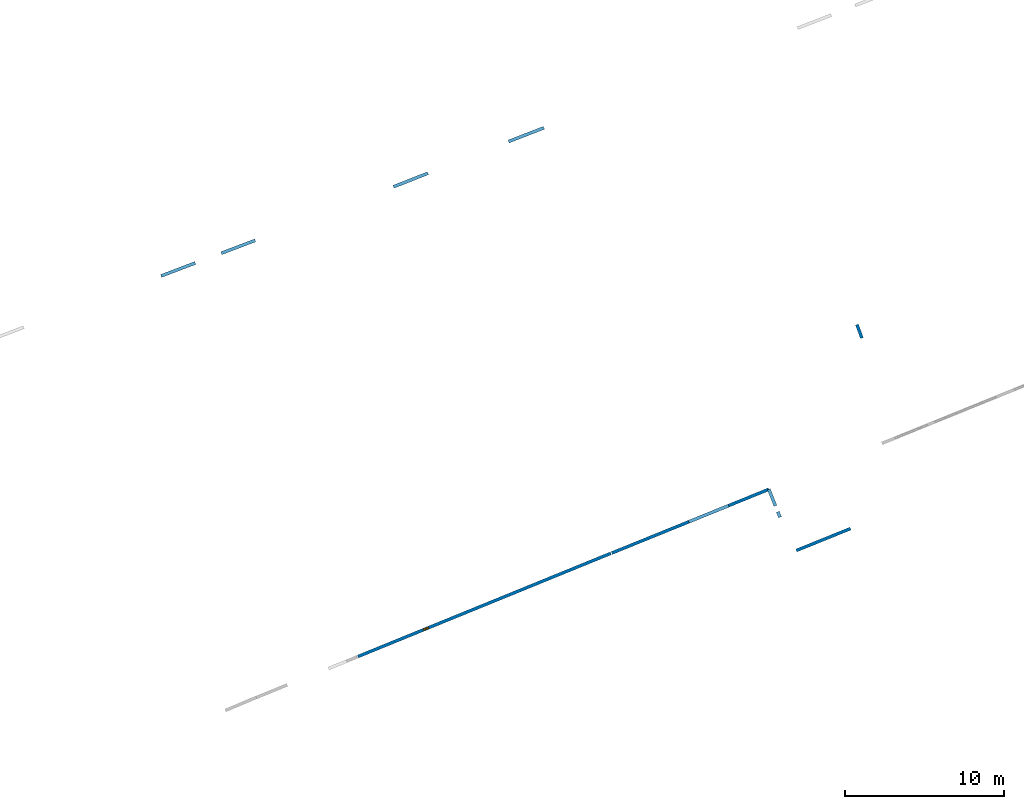
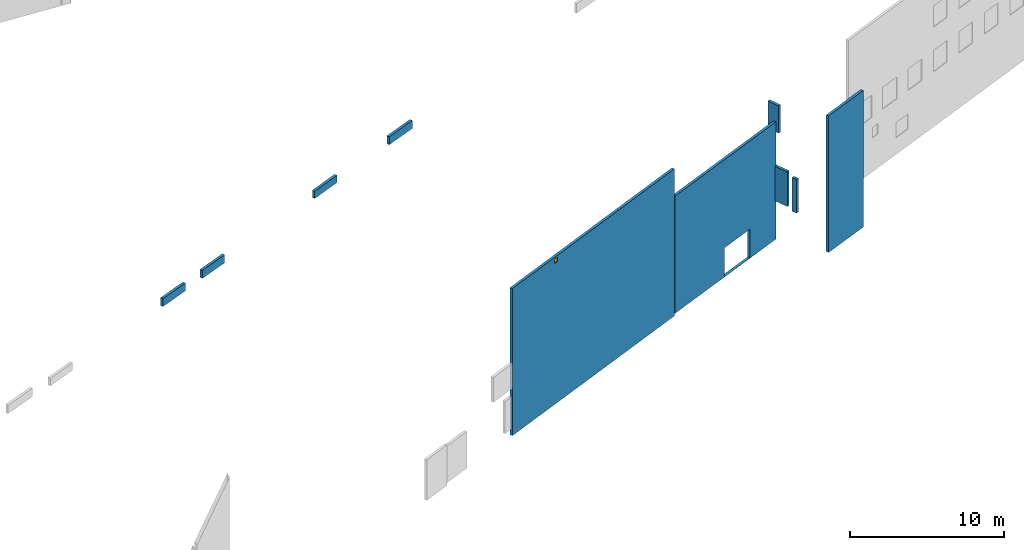
# One storey, part 3 of 27: 10 walls, 1 window, 2 openings.
"""IFC2X3 building model written with IfcOpenShell, lengths in metres."""

import ifcopenshell
import ifcopenshell.guid

model = None  # the IFC model being written
_history = None  # IfcOwnerHistory: only IFC2X3 demands one
_inside = {}  # id of a spatial element -> (the spatial element, [elements in it])
_under = {}  # id of a project, library or spatial element -> (it, [spatial elements below it])
_declared = {}  # id of a project -> (the project, [libraries it declares])
_typed = {}  # id of a type object -> (the type object, [elements of that type])
_made_of = {}  # id of a material, layer set ... -> (it, [elements and type objects made of it])


def new_model(schema):
    """Start an empty IFC model of exactly this schema.

    Asked for "IFC4X3", IfcOpenShell would pick the latest addendum, in which some entities
    have other attributes; the version numbers below select the first issue.
    IFC2X3 requires an IfcOwnerHistory on every rooted entity: one is made here for all.
    """
    global model, _history
    if schema == "IFC4X3":
        model = ifcopenshell.file(schema_version=(4, 3, 0, 0))
    else:
        model = ifcopenshell.file(schema=schema)
    _inside.clear()
    _under.clear()
    _declared.clear()
    _typed.clear()
    _made_of.clear()
    _history = None
    if model.schema == "IFC2X3":
        org = make("IfcOrganization", Name="unknown")
        user = make(
            "IfcPersonAndOrganization",
            ThePerson=make("IfcPerson", FamilyName="unknown"),
            TheOrganization=org,
        )
        app = make(
            "IfcApplication",
            ApplicationDeveloper=org,
            Version="unknown",
            ApplicationFullName="unknown",
            ApplicationIdentifier="unknown",
        )
        _history = make(
            "IfcOwnerHistory",
            OwningUser=user,
            OwningApplication=app,
            ChangeAction="ADDED",
            CreationDate=0,
        )
    return model


def make(cls, **values):
    """One entity of the class cls with the attributes given. An attribute that is None is left unset."""
    return model.create_entity(
        cls, **{name: value for name, value in values.items() if value is not None}
    )


def entity(cls, *values):
    """Any entity or typed value of the class cls, its attributes in the order of the schema. None: left unset."""
    e = model.create_entity(cls)
    for i, value in enumerate(values):
        if value is not None:
            e[i] = value
    return e


def rooted(cls, **values):
    """An entity with a GlobalId (a new one), such as an element, a storey or a relation."""
    return make(cls, GlobalId=ifcopenshell.guid.new(), OwnerHistory=_history, **values)


def si_unit(unit_type, name, prefix=None):
    """IfcSIUnit, for example si_unit("LENGTHUNIT", "METRE", prefix="MILLI")."""
    return make("IfcSIUnit", UnitType=unit_type, Prefix=prefix, Name=name)


def converted_unit(unit_type, name, factor, base, dimensions=None, offset=None):
    """IfcConversionBasedUnit, such as the inch: factor (a typed value) times the base unit."""
    return make(
        "IfcConversionBasedUnit"
        if offset is None
        else "IfcConversionBasedUnitWithOffset",
        ConversionOffset=offset,
        Dimensions=None
        if dimensions is None
        else entity("IfcDimensionalExponents", *dimensions),
        UnitType=unit_type,
        Name=name,
        ConversionFactor=make(
            "IfcMeasureWithUnit", ValueComponent=factor, UnitComponent=base
        ),
    )


def derived_unit(unit_type, elements):
    """IfcDerivedUnit: a product of units, each with its exponent."""
    return make(
        "IfcDerivedUnit",
        Elements=[
            make("IfcDerivedUnitElement", Unit=unit, Exponent=power)
            for unit, power in elements
        ],
        UnitType=unit_type,
    )


def assignment(units):
    """IfcUnitAssignment: the units of a project."""
    return None if units is None else make("IfcUnitAssignment", Units=units)


def point(xyz):
    """IfcCartesianPoint."""
    return None if xyz is None else make("IfcCartesianPoint", Coordinates=xyz)


def direction(xyz):
    """IfcDirection."""
    return None if xyz is None else make("IfcDirection", DirectionRatios=xyz)


def frame(location, z_axis=None, x_axis=None):
    """IfcAxis2Placement3D, a coordinate frame: its origin and axes. An axis left out is left unset."""
    return make(
        "IfcAxis2Placement3D",
        Location=point(location),
        Axis=direction(z_axis),
        RefDirection=direction(x_axis),
    )


def frame_2d(location, x_axis=None):
    """IfcAxis2Placement2D, a coordinate frame in the plane: its origin and x axis."""
    return make(
        "IfcAxis2Placement2D", Location=point(location), RefDirection=direction(x_axis)
    )


def origin():
    """The frame at (0, 0, 0) with its axes left unset."""
    return frame((0.0, 0.0, 0.0))


def origin_2d_with_axis():
    """The frame at (0, 0) in the plane with the x axis (1, 0) written out."""
    return frame_2d((0.0, 0.0), x_axis=(1.0, 0.0))


def place(relative_to, where):
    """IfcLocalPlacement: puts the frame where relative to a parent placement (None: the world)."""
    return make(
        "IfcLocalPlacement", PlacementRelTo=relative_to, RelativePlacement=where
    )


def context(
    kind, dimensions, precision=None, world=None, true_north=None, identifier=None
):
    """IfcGeometricRepresentationContext, for example the 3D "Model" context."""
    return make(
        "IfcGeometricRepresentationContext",
        ContextIdentifier=identifier,
        ContextType=kind,
        CoordinateSpaceDimension=dimensions,
        Precision=precision,
        WorldCoordinateSystem=world,
        TrueNorth=true_north,
    )


def subcontext(parent, identifier, kind, view, scale=None):
    """IfcGeometricRepresentationSubContext, for example "Body" below "Model"."""
    return make(
        "IfcGeometricRepresentationSubContext",
        ContextIdentifier=identifier,
        ContextType=kind,
        ParentContext=parent,
        TargetScale=scale,
        TargetView=view,
    )


def project(units=None, contexts=None):
    """IfcProject with its units and contexts."""
    return rooted(
        "IfcProject",
        Name="project",
        RepresentationContexts=contexts,
        UnitsInContext=assignment(units),
    )


def spatial(cls, under=None, at=None, **own):
    """A site, building, storey or space (cls), placed at a placement, below another one or the project."""
    s = rooted(cls, ObjectPlacement=at, **own)
    if under is not None:
        _under.setdefault(under.id(), (under, []))[1].append(s)
    return s


def polyline(points):
    """IfcPolyline through the points."""
    return make("IfcPolyline", Points=[point(p) for p in points])


def profile(cls, at=None, kind="AREA", **sizes):
    """A parametric profile (cls). Its sizes go by their IFC names, for example OverallWidth=200.0."""
    return make(cls, ProfileType=kind, Position=at, **sizes)


def rectangle(**sizes):
    """IfcRectangleProfileDef."""
    return profile("IfcRectangleProfileDef", **sizes)


def outline(outer, holes=None, kind="AREA"):
    """IfcArbitraryClosedProfileDef: a profile drawn as a closed curve; with holes, ...WithVoids."""
    if holes is None:
        return make("IfcArbitraryClosedProfileDef", ProfileType=kind, OuterCurve=outer)
    return make(
        "IfcArbitraryProfileDefWithVoids",
        ProfileType=kind,
        OuterCurve=outer,
        InnerCurves=holes,
    )


def extrude(swept, where, along, depth):
    """IfcExtrudedAreaSolid: the profile swept, set in the frame where, extruded along a direction by depth."""
    return make(
        "IfcExtrudedAreaSolid",
        SweptArea=swept,
        Position=where,
        ExtrudedDirection=direction(along),
        Depth=depth,
    )


def shape(context_of_items, identifier, shape_type, items):
    """IfcShapeRepresentation: the items that make up one representation, for example the "Body"."""
    return make(
        "IfcShapeRepresentation",
        ContextOfItems=context_of_items,
        RepresentationIdentifier=identifier,
        RepresentationType=shape_type,
        Items=items,
    )


def source(mapping_origin, context_of_items, identifier, shape_type, items):
    """IfcRepresentationMap: a shape defined once, which mapped items show again and again."""
    return make(
        "IfcRepresentationMap",
        MappingOrigin=mapping_origin,
        MappedRepresentation=shape(context_of_items, identifier, shape_type, items),
    )


def transform(
    local_origin,
    x_axis=None,
    y_axis=None,
    z_axis=None,
    scale=None,
    scale2=None,
    scale3=None,
    uniform=True,
):
    """IfcCartesianTransformationOperator3D, or its non-uniform kind. x_axis, y_axis, z_axis: its Axis1, 2, 3."""
    if uniform:
        return make(
            "IfcCartesianTransformationOperator3D",
            Axis1=direction(x_axis),
            Axis2=direction(y_axis),
            LocalOrigin=point(local_origin),
            Scale=scale,
            Axis3=direction(z_axis),
        )
    return make(
        "IfcCartesianTransformationOperator3DnonUniform",
        Axis1=direction(x_axis),
        Axis2=direction(y_axis),
        LocalOrigin=point(local_origin),
        Scale=scale,
        Axis3=direction(z_axis),
        Scale2=scale2,
        Scale3=scale3,
    )


def mapped(mapping_source, mapping_target):
    """IfcMappedItem: shows the shape of a source again, moved by a transform."""
    return make(
        "IfcMappedItem", MappingSource=mapping_source, MappingTarget=mapping_target
    )


def material(Name=None, Category=None):
    """IfcMaterial."""
    return make("IfcMaterial", Name=Name, Category=Category)


def layer(
    of_material, thickness, ventilated=None, Name=None, Category=None, Priority=None
):
    """IfcMaterialLayer: one layer of a wall or slab, of a material (None: an air gap)."""
    return make(
        "IfcMaterialLayer",
        Material=of_material,
        LayerThickness=thickness,
        IsVentilated=ventilated,
        Name=Name,
        Category=Category,
        Priority=Priority,
    )


def layer_set(layers, Name=None):
    """IfcMaterialLayerSet."""
    return make("IfcMaterialLayerSet", MaterialLayers=layers, LayerSetName=Name)


def layer_usage(for_layer_set, set_direction, sense, offset, extent=None):
    """IfcMaterialLayerSetUsage: how a layer set lies in its element."""
    return make(
        "IfcMaterialLayerSetUsage",
        ForLayerSet=for_layer_set,
        LayerSetDirection=set_direction,
        DirectionSense=sense,
        OffsetFromReferenceLine=offset,
        ReferenceExtent=extent,
    )


def made_of(thing, what):
    """Note that an element or type object is made of a material, layer set ...; save() writes the relation."""
    if what is not None:
        _made_of.setdefault(what.id(), (what, []))[1].append(thing)
    return thing


def type_object(cls, material=None, **own):
    """A type object (cls), such as IfcWallType, which elements share."""
    return made_of(rooted(cls, **own), material)


def type_shapes(of_type, sources):
    """Give a type object the sources (RepresentationMaps) that its elements show as mapped items."""
    of_type.RepresentationMaps = sources


def element(
    cls,
    number,
    at=None,
    inside=None,
    cuts=None,
    type_object=None,
    material=None,
    context=None,
    identifier="Body",
    shape_type=None,
    held_by="IfcProductDefinitionShape",
    body=None,
    shapes=None,
    **own,
):
    """One element of the class cls, such as IfcWall. Its Tag is "e" and its number.

    at: its placement. inside: the storey or other place that contains it. cuts: it is an
    opening in that element (IfcRelVoidsElement). A single representation is given by context,
    identifier, shape_type and body (its items); several are given by shapes. held_by: the class
    of the entity that holds the representations. save() writes the other relations.
    """
    e = rooted(cls, Tag="e%d" % number, ObjectPlacement=at, **own)
    if body is not None:
        shapes = [shape(context, identifier, shape_type, body)]
    if shapes is not None:
        e.Representation = make(held_by, Representations=shapes)
    if inside is not None:
        _inside.setdefault(inside.id(), (inside, []))[1].append(e)
    if cuts is not None:
        rooted(
            "IfcRelVoidsElement", RelatingBuildingElement=cuts, RelatedOpeningElement=e
        )
    if type_object is not None:
        _typed.setdefault(type_object.id(), (type_object, []))[1].append(e)
    return made_of(e, material)


def fill(opening, filler):
    """IfcRelFillsElement: the door or window that sits in an opening."""
    return rooted(
        "IfcRelFillsElement",
        RelatingOpeningElement=opening,
        RelatedBuildingElement=filler,
    )


def aggregate(whole, parts):
    """IfcRelAggregates: a whole, such as a stair, and the parts it consists of."""
    return rooted("IfcRelAggregates", RelatingObject=whole, RelatedObjects=parts)


def save(model, path):
    """Write the relations noted so far, then the file.

    IfcRelAggregates (storeys below a building ...), IfcRelContainedInSpatialStructure (elements
    in a storey), IfcRelDefinesByType, IfcRelAssociatesMaterial and IfcRelDeclares: one each for
    every whole, place, type object, material and project.
    """
    for whole, parts in _under.values():
        aggregate(whole, parts)
    for where, things in _inside.values():
        rooted(
            "IfcRelContainedInSpatialStructure",
            RelatedElements=things,
            RelatingStructure=where,
        )
    for kind, things in _typed.values():
        rooted("IfcRelDefinesByType", RelatedObjects=things, RelatingType=kind)
    for what, things in _made_of.values():
        rooted("IfcRelAssociatesMaterial", RelatedObjects=things, RelatingMaterial=what)
    for by, libraries in _declared.values():
        rooted("IfcRelDeclares", RelatingContext=by, RelatedDefinitions=libraries)
    model.write(path)


model = new_model("IFC2X3")

# Units and contexts
model_context = context("Model", 3, precision=1e-05, world=origin(), true_north=direction((0.0, 1.0)))
body_context = subcontext(model_context, "Body", "Model", "MODEL_VIEW")
ifc_project = project(units=[si_unit("LENGTHUNIT", "METRE"), si_unit("AREAUNIT", "SQUARE_METRE"), si_unit("VOLUMEUNIT", "CUBIC_METRE"), converted_unit("PLANEANGLEUNIT", "DEGREE", entity("IfcRatioMeasure", 0.0174532925199433), si_unit("PLANEANGLEUNIT", "RADIAN"), dimensions=[0, 0, 0, 0, 0, 0, 0]), si_unit("MASSUNIT", "GRAM", prefix="KILO"), derived_unit("MASSDENSITYUNIT", [(si_unit("MASSUNIT", "GRAM", prefix="KILO"), 1), (si_unit("LENGTHUNIT", "METRE"), -3)]), derived_unit("MOMENTOFINERTIAUNIT", [(si_unit("LENGTHUNIT", "METRE"), 4)]), si_unit("TIMEUNIT", "SECOND"), si_unit("FREQUENCYUNIT", "HERTZ"), si_unit("THERMODYNAMICTEMPERATUREUNIT", "DEGREE_CELSIUS"), derived_unit("THERMALTRANSMITTANCEUNIT", [(si_unit("MASSUNIT", "GRAM", prefix="KILO"), 1), (si_unit("THERMODYNAMICTEMPERATUREUNIT", "KELVIN"), -1), (si_unit("TIMEUNIT", "SECOND"), -3)]), derived_unit("VOLUMETRICFLOWRATEUNIT", [(si_unit("LENGTHUNIT", "METRE"), 3), (si_unit("TIMEUNIT", "SECOND"), -1)]), si_unit("ELECTRICCURRENTUNIT", "AMPERE"), si_unit("ELECTRICVOLTAGEUNIT", "VOLT"), si_unit("POWERUNIT", "WATT"), si_unit("FORCEUNIT", "NEWTON", prefix="KILO"), si_unit("ILLUMINANCEUNIT", "LUX"), si_unit("LUMINOUSFLUXUNIT", "LUMEN"), si_unit("LUMINOUSINTENSITYUNIT", "CANDELA"), derived_unit("USERDEFINED", [(si_unit("MASSUNIT", "GRAM", prefix="KILO"), -1), (si_unit("LENGTHUNIT", "METRE"), -2), (si_unit("TIMEUNIT", "SECOND"), 3), (si_unit("LUMINOUSFLUXUNIT", "LUMEN"), 1)]), derived_unit("LINEARVELOCITYUNIT", [(si_unit("LENGTHUNIT", "METRE"), 1), (si_unit("TIMEUNIT", "SECOND"), -1)]), si_unit("PRESSUREUNIT", "PASCAL"), derived_unit("USERDEFINED", [(si_unit("LENGTHUNIT", "METRE"), -2), (si_unit("MASSUNIT", "GRAM", prefix="KILO"), 1), (si_unit("TIMEUNIT", "SECOND"), -2)]), derived_unit("LINEARFORCEUNIT", [(si_unit("MASSUNIT", "GRAM", prefix="KILO"), 1), (si_unit("LENGTHUNIT", "METRE"), 1), (si_unit("TIMEUNIT", "SECOND"), -2), (si_unit("LENGTHUNIT", "METRE"), -1)]), derived_unit("PLANARFORCEUNIT", [(si_unit("MASSUNIT", "GRAM", prefix="KILO"), 1), (si_unit("LENGTHUNIT", "METRE"), 1), (si_unit("TIMEUNIT", "SECOND"), -2), (si_unit("LENGTHUNIT", "METRE"), -2)])], contexts=[model_context])

# Site, building, storey
placement_1 = place(None, origin())
site = spatial("IfcSite", under=ifc_project, at=placement_1, CompositionType="ELEMENT")
building = spatial("IfcBuilding", under=site, at=placement_1, CompositionType="ELEMENT")
storey_placement = place(placement_1, frame((0.0, 0.0, -61.043098449707)))
storey = spatial("IfcBuildingStorey", under=building, at=storey_placement, Name="level_-61.043098", CompositionType="ELEMENT", Elevation=-61.043098449707)

# Walls
ifc_material_1 = material(Name="Default wall")
ifc_layer = layer(ifc_material_1, 0.2)
ifc_layer_set = layer_set([ifc_layer], Name="wall_thickness_0.2000")
ifc_layer_usage = layer_usage(ifc_layer_set, "AXIS2", "POSITIVE", -0.1)
wall_type = type_object("IfcWallType", Name="wall_thickness_0.2000", PredefinedType="STANDARD", material=ifc_layer_set)
placement_2 = place(placement_1, frame((0.0, 0.0, -60.7112045288086)))
wall_1_placement = place(placement_2, frame((-34.5549320102655, -43.5222577271523, 0.0), z_axis=(0.0, 0.0, 1.0), x_axis=(0.930127320386942, 0.367237209266444, 0.0)))
element("IfcWallStandardCase", 1, at=wall_1_placement, inside=storey, type_object=wall_type, material=ifc_layer_usage, Name="Wall:374", ObjectType="Wall", context=body_context, shape_type="SweptSolid", body=[
    extrude(outline(polyline([(2.33000163918502, -0.1), (2.33000163918502, 0.1), (0.0, 0.1), (0.0, -0.1), (2.33000163918502, -0.1)])), origin(), (0.0, 0.0, 1.0), 0.577728271484375),
])
placement_3 = place(placement_1, frame((0.0, 0.0, -60.0665283203125)))
wall_2_placement = place(placement_3, frame((-5.02439694069814, -53.0608902471777, 0.0), z_axis=(0.0, 0.0, 1.0), x_axis=(-0.347366852816646, 0.937729315721898, 0.0)))
element("IfcWallStandardCase", 2, at=wall_2_placement, inside=storey, type_object=wall_type, material=ifc_layer_usage, Name="Wall:553", ObjectType="Wall", context=body_context, shape_type="SweptSolid", body=[
    extrude(outline(polyline([(0.91499835622625, -0.1), (0.91499835622625, 0.1), (0.0, 0.1), (0.0, -0.1), (0.91499835622625, -0.1)])), origin(), (0.0, 0.0, 1.0), 2.16623687744141),
])

# Wall, opening
placement_4 = place(placement_1, frame((0.0, 0.0, -60.6535377502441)))
wall_3_placement = place(placement_4, frame((-10.896544728658, -62.590907767994, 0.0), z_axis=(0.0, 0.0, 1.0), x_axis=(-0.926550787354536, -0.376169693692474, 0.0)))
wall_3 = element("IfcWallStandardCase", 3, at=wall_3_placement, inside=storey, type_object=wall_type, material=ifc_layer_usage, Name="Wall:817", ObjectType="Wall", context=body_context, shape_type="SweptSolid", body=[
    extrude(outline(polyline([(10.6870224783565, -0.1), (10.6870224783565, 0.1), (0.0, 0.1), (0.0, -0.1), (10.6870224783565, -0.1)])), origin(), (0.0, 0.0, 1.0), 9.32137680053711),
])
opening_1_placement = place(wall_3_placement, frame((2.73702170019746, -0.1, 0.0244483947753906)))
element("IfcOpeningElement", 4, at=opening_1_placement, cuts=wall_3, Name="Opening : 2710 x 2290 : 79", ObjectType="Opening", context=body_context, shape_type="SweptSolid", body=[
    extrude(rectangle(XDim=2.71, YDim=2.29, at=frame_2d((1.145, 1.355), x_axis=(0.0, 1.0))), frame((0.0, 0.0, 0.0), z_axis=(0.0, 1.0, 0.0), x_axis=(0.0, 0.0, 1.0)), (0.0, 0.0, 1.0), 0.2),
])

# Wall, opening, window
placement_5 = place(placement_1, frame((0.0, 0.0, -60.8194160461426)))
wall_4_placement = place(placement_5, frame((-36.7856763548455, -73.128617904915, 0.0), z_axis=(0.0, 0.0, 1.0), x_axis=(0.925840647308533, 0.377914138120441, 0.0)))
wall_4 = element("IfcWallStandardCase", 5, at=wall_4_placement, inside=storey, type_object=wall_type, material=ifc_layer_usage, Name="Wall:924", ObjectType="Wall", context=body_context, shape_type="SweptSolid", body=[
    extrude(outline(polyline([(17.2081934717658, -0.1), (17.2081934717658, 0.1), (0.0, 0.1), (0.0, -0.1), (17.2081934717658, -0.1)])), origin(), (0.0, 0.0, 1.0), 11.6870231628418),
])
opening_2_placement = place(wall_4_placement, frame((4.45819592529137, -0.1, 11.2158889770508)))
opening_2 = element("IfcOpeningElement", 6, at=opening_2_placement, cuts=wall_4, Name="Opening : 335 x 315 : 108", ObjectType="Opening", context=body_context, shape_type="SweptSolid", body=[
    extrude(rectangle(XDim=0.335, YDim=0.315, at=frame_2d((0.1575, 0.1675), x_axis=(0.0, 1.0))), frame((0.0, 0.0, 0.0), z_axis=(0.0, 1.0, 0.0), x_axis=(0.0, 0.0, 1.0)), (0.0, 0.0, 1.0), 0.2),
])
ifc_material_2 = material(Name="Window Default")
window_style = type_object("IfcWindowStyle", Name="Window : 335 x 315mm", ConstructionType="NOTDEFINED", OperationType="NOTDEFINED", ParameterTakesPrecedence=False, Sizeable=False, material=ifc_material_2)
shared_shape = source(origin(), body_context, "Body", "SweptSolid", [
    extrude(rectangle(XDim=0.1, YDim=0.335, at=origin_2d_with_axis()), frame((0.1675, 0.1, 0.0), z_axis=(0.0, 0.0, 1.0), x_axis=(0.0, 1.0, 0.0)), (0.0, 0.0, 1.0), 0.315),
])
type_shapes(window_style, [shared_shape])
window_placement = place(opening_2_placement, origin())
window = element("IfcWindow", 7, at=window_placement, inside=storey, type_object=window_style, Name="Window : 335 x 315mm : 96", ObjectType="Window : 335 x 315mm", OverallHeight=0.315, OverallWidth=0.335, context=body_context, shape_type="MappedRepresentation", body=[
    mapped(shared_shape, transform((0.0, 0.0, 0.0), scale=1.0)),
])
fill(opening_2, window)

# Walls
placement_6 = place(placement_1, frame((0.0, 0.0, -60.7575225830078)))
wall_5_placement = place(placement_6, frame((-49.2015543432284, -49.1419291612226, 0.0), z_axis=(0.0, 0.0, 1.0), x_axis=(0.934596079628284, 0.35571079255969, 0.0)))
element("IfcWallStandardCase", 8, at=wall_5_placement, inside=storey, type_object=wall_type, material=ifc_layer_usage, Name="Wall:1118", ObjectType="Wall", context=body_context, shape_type="SweptSolid", body=[
    extrude(outline(polyline([(2.3037627301231, -0.1), (2.3037627301231, 0.1), (0.0, 0.1), (0.0, -0.1), (2.3037627301231, -0.1)])), origin(), (0.0, 0.0, 1.0), 0.624046325683594),
])
placement_7 = place(placement_1, frame((0.0, 0.0, -60.7112045288086)))
wall_6_placement = place(placement_7, frame((-27.2980173145316, -40.6654574978525, 0.0), z_axis=(0.0, 0.0, 1.0), x_axis=(0.932452784279287, 0.361291855830996, 0.0)))
element("IfcWallStandardCase", 9, at=wall_6_placement, inside=storey, type_object=wall_type, material=ifc_layer_usage, Name="Wall:1392", ObjectType="Wall", context=body_context, shape_type="SweptSolid", body=[
    extrude(outline(polyline([(2.38999919238773, -0.1), (2.38999919238773, 0.1), (0.0, 0.1), (0.0, -0.1), (2.38999919238773, -0.1)])), origin(), (0.0, 0.0, 1.0), 0.635761260986328),
])
placement_8 = place(placement_1, frame((0.0, 0.0, -57.764591217041)))
wall_7_placement = place(placement_8, frame((-10.1896236025903, -64.3535244092749, 0.0), z_axis=(0.0, 0.0, 1.0), x_axis=(-0.372238958608524, 0.928136928310711, 0.0)))
element("IfcWallStandardCase", 10, at=wall_7_placement, inside=storey, type_object=wall_type, material=ifc_layer_usage, Name="Wall:1432", ObjectType="Wall", context=body_context, shape_type="SweptSolid", body=[
    extrude(outline(polyline([(0.375001756636396, -0.1), (0.375001756636396, 0.1), (0.0, 0.1), (0.0, -0.1), (0.375001756636396, -0.1)])), origin(), (0.0, 0.0, 1.0), 2.67841720581055),
])
placement_9 = place(placement_1, frame((0.0, 0.0, -57.5610122680664)))
wall_8_placement = place(placement_9, frame((-10.4781100833032, -63.6342174634741, 0.0), z_axis=(0.0, 0.0, 1.0), x_axis=(-0.37223950372015, 0.928136709687844, 0.0)))
element("IfcWallStandardCase", 11, at=wall_8_placement, inside=storey, type_object=wall_type, material=ifc_layer_usage, Name="Wall:1433", ObjectType="Wall", context=body_context, shape_type="SweptSolid", body=[
    extrude(outline(polyline([(1.12408899159643, -0.1), (1.12408899159643, 0.1), (0.0, 0.1), (0.0, -0.1), (1.12408899159643, -0.1)])), origin(), (0.0, 0.0, 1.0), 2.74881362915039),
])
placement_10 = place(placement_1, frame((0.0, 0.0, -60.7112045288086)))
wall_9_placement = place(placement_10, frame((-45.4078473721426, -47.7092293369948, 0.0), z_axis=(0.0, 0.0, 1.0), x_axis=(0.935067361845271, 0.354470067582195, 0.0)))
element("IfcWallStandardCase", 12, at=wall_9_placement, inside=storey, type_object=wall_type, material=ifc_layer_usage, Name="Wall:1459", ObjectType="Wall", context=body_context, shape_type="SweptSolid", body=[
    extrude(outline(polyline([(2.28543875208419, -0.1), (2.28543875208419, 0.1), (0.0, 0.1), (0.0, -0.1), (2.28543875208419, -0.1)])), origin(), (0.0, 0.0, 1.0), 0.635761260986328),
])
placement_11 = place(placement_1, frame((0.0, 0.0, -59.9867630004883)))
wall_10_placement = place(placement_11, frame((-9.15975946159807, -66.4482505447664, 0.0), z_axis=(0.0, 0.0, 1.0), x_axis=(0.926824606563679, 0.375494538799275, 0.0)))
element("IfcWallStandardCase", 13, at=wall_10_placement, inside=storey, type_object=wall_type, material=ifc_layer_usage, Name="Wall:1634", ObjectType="Wall", context=body_context, shape_type="SweptSolid", body=[
    extrude(outline(polyline([(3.68500035763581, -0.1), (3.68500035763581, 0.1), (0.0, 0.1), (0.0, -0.1), (3.68500035763581, -0.1)])), origin(), (0.0, 0.0, 1.0), 10.8543701171875),
])

save(model, "model.ifc")
